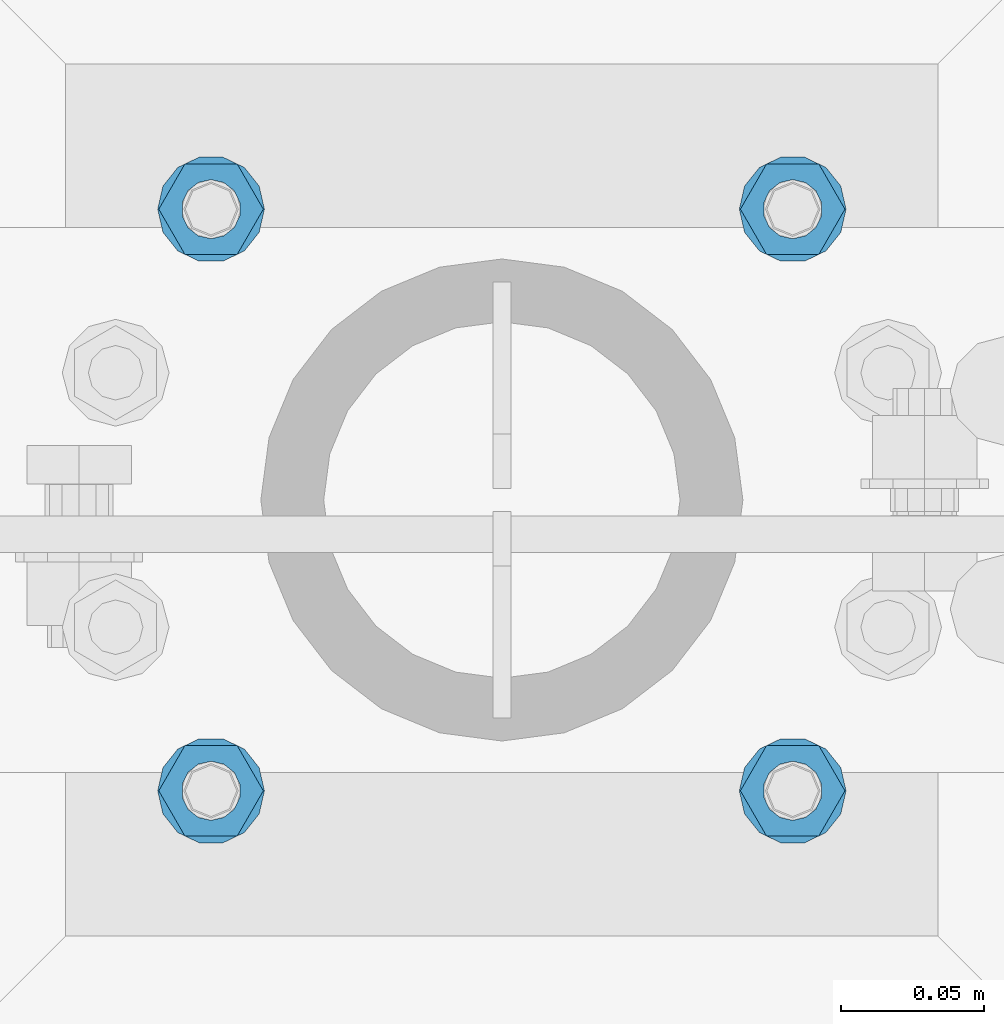
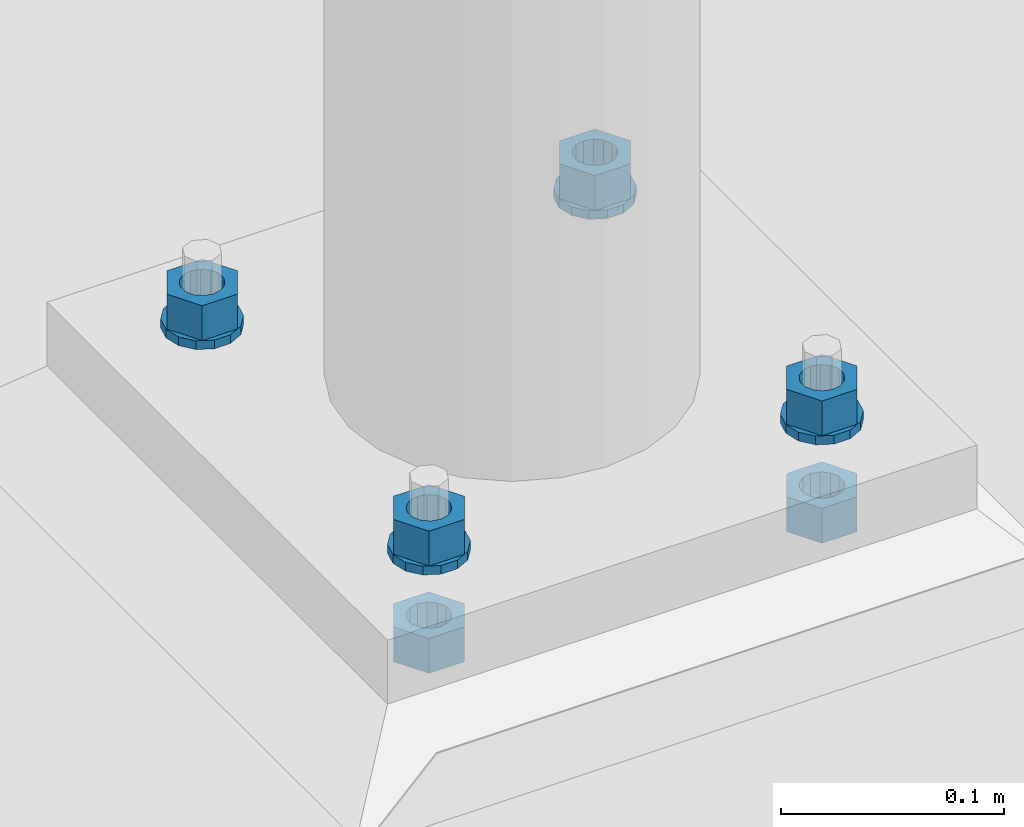
# One storey, part 579 of 975: 10 beams.
"""IFC2X3 building model written with IfcOpenShell, lengths in millimetres."""

from ifc_helpers import new_model, si_unit, frame, origin_with_axes, place, context, subcontext, project, spatial, faceted_brep, material, type_object, element, save


model = new_model("IFC2X3")

# Units and contexts
model_context = context("Model", 3, precision=1e-05, world=origin_with_axes())
body_context = subcontext(model_context, "Body", "Model", "MODEL_VIEW")
ifc_project = project(units=[si_unit("LENGTHUNIT", "METRE", prefix="MILLI"), si_unit("AREAUNIT", "SQUARE_METRE"), si_unit("VOLUMEUNIT", "CUBIC_METRE"), si_unit("MASSUNIT", "GRAM", prefix="KILO"), si_unit("TIMEUNIT", "SECOND"), si_unit("PLANEANGLEUNIT", "RADIAN"), si_unit("SOLIDANGLEUNIT", "STERADIAN"), si_unit("THERMODYNAMICTEMPERATUREUNIT", "DEGREE_CELSIUS"), si_unit("LUMINOUSINTENSITYUNIT", "LUMEN")], contexts=[model_context])

# Site, building, storey
site_placement = place(None, origin_with_axes())
site = spatial("IfcSite", under=ifc_project, at=site_placement, CompositionType="ELEMENT")
building_placement = place(site_placement, origin_with_axes())
building = spatial("IfcBuilding", under=site, at=building_placement, Name="Undefined", CompositionType="ELEMENT")
storey_placement = place(building_placement, origin_with_axes())
storey = spatial("IfcBuildingStorey", under=building, at=storey_placement, Name="Undefined", CompositionType="ELEMENT", Elevation=0.0)

# Beams
ifc_material = material(Name="STEEL/A36")
beam_type_1 = type_object("IfcBeamType", Name="3/4_WASHER", PredefinedType="NOTDEFINED")
beam_1_placement = place(storey_placement, frame((23131.4625015259, 5718.17500305176, -227.0125), z_axis=(0.0, -1.0, 0.0), x_axis=(0.0, 0.0, -1.0)))
element("IfcBeam", 1, at=beam_1_placement, inside=storey, type_object=beam_type_1, material=ifc_material, Name="WASHER", ObjectType="3/4_WASHER", context=body_context, shape_type="Brep", body=[
    faceted_brep([(0.0, -18.6499996185303, 0.0), (0.0, -16.8030690426876, -8.09193156902904), (4.76250000000073, -16.8030690426876, -8.09193156902904), (4.76250000000073, -18.6499996185303, 0.0), (0.0, -11.6280845668225, -14.5811568497838), (4.76250000000073, -11.6280845668225, -14.5811568497838), (0.0, -4.15001533340001, -18.1824051902857), (4.76250000000073, -4.15001533340001, -18.1824051902857), (0.0, 4.15001533340001, -18.1824051902857), (4.76250000000073, 4.15001533340001, -18.1824051902857), (0.0, 11.6280845668234, -14.5811568497838), (4.76250000000073, 11.6280845668234, -14.5811568497838), (0.0, 16.8030690426876, -8.09193156902904), (4.76250000000073, 16.8030690426876, -8.09193156902904), (0.0, 18.6499996185303, 0.0), (4.76250000000073, 18.6499996185303, 0.0), (0.0, 16.8030690426876, 8.09193156902904), (4.76250000000073, 16.8030690426876, 8.09193156902904), (0.0, 11.6280845668225, 14.5811568497838), (4.76250000000073, 11.6280845668225, 14.5811568497838), (0.0, 4.15001533340001, 18.1824051902857), (4.76250000000073, 4.15001533340001, 18.1824051902857), (0.0, -4.15001533340001, 18.1824051902857), (4.76250000000073, -4.15001533340001, 18.1824051902857), (0.0, -11.6280845668234, 14.5811568497838), (4.76250000000073, -11.6280845668234, 14.5811568497838), (0.0, -16.8030690426876, 8.09193156902904), (4.76250000000073, -16.8030690426876, 8.09193156902904), (0.0, 0.0, 10.3199996948242), (0.0, 4.47768005528269, 9.29799844179911), (4.76250000000073, 4.47768005528269, 9.29799844179911), (4.76250000000073, 0.0, 10.3199996948242), (0.0, 8.06850066047446, 6.43441456490817), (4.76250000000073, 8.06850066047446, 6.43441456490817), (0.0, 10.0612557561917, 2.29641597052117), (4.76250000000073, 10.0612557561917, 2.29641597052117), (0.0, 10.0612557561917, -2.29641597052117), (4.76250000000073, 10.0612557561917, -2.29641597052117), (0.0, 8.06850066047446, -6.43441456490814), (4.76250000000073, 8.06850066047446, -6.43441456490814), (0.0, 4.47768005528269, -9.29799844179908), (4.76250000000073, 4.47768005528269, -9.29799844179908), (0.0, 0.0, -10.3199996948242), (4.76250000000073, 0.0, -10.3199996948242), (0.0, -4.47768005528269, -9.29799844179911), (4.76250000000073, -4.47768005528269, -9.29799844179911), (0.0, -8.06850066047446, -6.43441456490817), (4.76250000000073, -8.06850066047446, -6.43441456490817), (0.0, -10.0612557561917, -2.29641597052117), (4.76250000000073, -10.0612557561917, -2.29641597052117), (0.0, -10.0612557561917, 2.29641597052117), (4.76250000000073, -10.0612557561917, 2.29641597052117), (0.0, -8.06850066047446, 6.43441456490814), (4.76250000000073, -8.06850066047446, 6.43441456490814), (0.0, -4.47768005528269, 9.29799844179908), (4.76250000000073, -4.47768005528269, 9.29799844179908)], [[[0, 1, 2, 3]], [[1, 4, 5, 2]], [[4, 6, 7, 5]], [[6, 8, 9, 7]], [[8, 10, 11, 9]], [[10, 12, 13, 11]], [[12, 14, 15, 13]], [[14, 16, 17, 15]], [[16, 18, 19, 17]], [[18, 20, 21, 19]], [[20, 22, 23, 21]], [[22, 24, 25, 23]], [[24, 26, 27, 25]], [[26, 0, 3, 27]], [[28, 29, 30, 31]], [[29, 32, 33, 30]], [[32, 34, 35, 33]], [[34, 36, 37, 35]], [[36, 38, 39, 37]], [[38, 40, 41, 39]], [[40, 42, 43, 41]], [[42, 44, 45, 43]], [[44, 46, 47, 45]], [[46, 48, 49, 47]], [[48, 50, 51, 49]], [[50, 52, 53, 51]], [[52, 54, 55, 53]], [[54, 28, 31, 55]], [[5, 7, 9, 11, 13, 15, 17, 19, 21, 23, 25, 27, 3, 2], [33, 35, 37, 39, 41, 43, 45, 47, 49, 51, 53, 55, 31, 30]], [[26, 24, 22, 20, 18, 16, 14, 12, 10, 8, 6, 4, 1, 0], [54, 52, 50, 48, 46, 44, 42, 40, 38, 36, 34, 32, 29, 28]]]),
])
beam_2_placement = place(storey_placement, frame((23334.6624984741, 5718.17500305176, -227.0125), z_axis=(0.0, 1.0, 0.0), x_axis=(0.0, 0.0, -1.0)))
element("IfcBeam", 2, at=beam_2_placement, inside=storey, type_object=beam_type_1, material=ifc_material, Name="WASHER", ObjectType="3/4_WASHER", context=body_context, shape_type="Brep", body=[
    faceted_brep([(0.0, -18.6499996185303, 0.0), (0.0, -16.8030690426876, -8.09193156902904), (4.76250000000073, -16.8030690426876, -8.09193156902904), (4.76250000000073, -18.6499996185303, 0.0), (0.0, -11.6280845668225, -14.5811568497838), (4.76250000000073, -11.6280845668225, -14.5811568497838), (0.0, -4.15001533340001, -18.1824051902857), (4.76250000000073, -4.15001533340001, -18.1824051902857), (0.0, 4.15001533340001, -18.1824051902857), (4.76250000000073, 4.15001533340001, -18.1824051902857), (0.0, 11.6280845668234, -14.5811568497838), (4.76250000000073, 11.6280845668234, -14.5811568497838), (0.0, 16.8030690426876, -8.09193156902904), (4.76250000000073, 16.8030690426876, -8.09193156902904), (0.0, 18.6499996185303, 0.0), (4.76250000000073, 18.6499996185303, 0.0), (0.0, 16.8030690426876, 8.09193156902904), (4.76250000000073, 16.8030690426876, 8.09193156902904), (0.0, 11.6280845668225, 14.5811568497838), (4.76250000000073, 11.6280845668225, 14.5811568497838), (0.0, 4.15001533340001, 18.1824051902857), (4.76250000000073, 4.15001533340001, 18.1824051902857), (0.0, -4.15001533340001, 18.1824051902857), (4.76250000000073, -4.15001533340001, 18.1824051902857), (0.0, -11.6280845668234, 14.5811568497838), (4.76250000000073, -11.6280845668234, 14.5811568497838), (0.0, -16.8030690426876, 8.09193156902904), (4.76250000000073, -16.8030690426876, 8.09193156902904), (0.0, 0.0, 10.3199996948242), (0.0, 4.47768005528269, 9.29799844179911), (4.76250000000073, 4.47768005528269, 9.29799844179911), (4.76250000000073, 0.0, 10.3199996948242), (0.0, 8.06850066047446, 6.43441456490817), (4.76250000000073, 8.06850066047446, 6.43441456490817), (0.0, 10.0612557561917, 2.29641597052117), (4.76250000000073, 10.0612557561917, 2.29641597052117), (0.0, 10.0612557561917, -2.29641597052117), (4.76250000000073, 10.0612557561917, -2.29641597052117), (0.0, 8.06850066047446, -6.43441456490814), (4.76250000000073, 8.06850066047446, -6.43441456490814), (0.0, 4.47768005528269, -9.29799844179908), (4.76250000000073, 4.47768005528269, -9.29799844179908), (0.0, 0.0, -10.3199996948242), (4.76250000000073, 0.0, -10.3199996948242), (0.0, -4.47768005528269, -9.29799844179911), (4.76250000000073, -4.47768005528269, -9.29799844179911), (0.0, -8.06850066047446, -6.43441456490817), (4.76250000000073, -8.06850066047446, -6.43441456490817), (0.0, -10.0612557561917, -2.29641597052117), (4.76250000000073, -10.0612557561917, -2.29641597052117), (0.0, -10.0612557561917, 2.29641597052117), (4.76250000000073, -10.0612557561917, 2.29641597052117), (0.0, -8.06850066047446, 6.43441456490814), (4.76250000000073, -8.06850066047446, 6.43441456490814), (0.0, -4.47768005528269, 9.29799844179908), (4.76250000000073, -4.47768005528269, 9.29799844179908)], [[[0, 1, 2, 3]], [[1, 4, 5, 2]], [[4, 6, 7, 5]], [[6, 8, 9, 7]], [[8, 10, 11, 9]], [[10, 12, 13, 11]], [[12, 14, 15, 13]], [[14, 16, 17, 15]], [[16, 18, 19, 17]], [[18, 20, 21, 19]], [[20, 22, 23, 21]], [[22, 24, 25, 23]], [[24, 26, 27, 25]], [[26, 0, 3, 27]], [[28, 29, 30, 31]], [[29, 32, 33, 30]], [[32, 34, 35, 33]], [[34, 36, 37, 35]], [[36, 38, 39, 37]], [[38, 40, 41, 39]], [[40, 42, 43, 41]], [[42, 44, 45, 43]], [[44, 46, 47, 45]], [[46, 48, 49, 47]], [[48, 50, 51, 49]], [[50, 52, 53, 51]], [[52, 54, 55, 53]], [[54, 28, 31, 55]], [[5, 7, 9, 11, 13, 15, 17, 19, 21, 23, 25, 27, 3, 2], [33, 35, 37, 39, 41, 43, 45, 47, 49, 51, 53, 55, 31, 30]], [[26, 24, 22, 20, 18, 16, 14, 12, 10, 8, 6, 4, 1, 0], [54, 52, 50, 48, 46, 44, 42, 40, 38, 36, 34, 32, 29, 28]]]),
])
beam_3_placement = place(storey_placement, frame((23131.4625015259, 5921.375, -227.0125), z_axis=(0.0, -1.0, 0.0), x_axis=(0.0, 0.0, -1.0)))
element("IfcBeam", 3, at=beam_3_placement, inside=storey, type_object=beam_type_1, material=ifc_material, Name="WASHER", ObjectType="3/4_WASHER", context=body_context, shape_type="Brep", body=[
    faceted_brep([(0.0, -18.6499996185303, 0.0), (0.0, -16.8030690426876, -8.09193156902904), (4.76250000000073, -16.8030690426876, -8.09193156902904), (4.76250000000073, -18.6499996185303, 0.0), (0.0, -11.6280845668225, -14.5811568497838), (4.76250000000073, -11.6280845668225, -14.5811568497838), (0.0, -4.15001533340001, -18.1824051902857), (4.76250000000073, -4.15001533340001, -18.1824051902857), (0.0, 4.15001533340001, -18.1824051902857), (4.76250000000073, 4.15001533340001, -18.1824051902857), (0.0, 11.6280845668234, -14.5811568497838), (4.76250000000073, 11.6280845668234, -14.5811568497838), (0.0, 16.8030690426876, -8.09193156902904), (4.76250000000073, 16.8030690426876, -8.09193156902904), (0.0, 18.6499996185303, 0.0), (4.76250000000073, 18.6499996185303, 0.0), (0.0, 16.8030690426876, 8.09193156902904), (4.76250000000073, 16.8030690426876, 8.09193156902904), (0.0, 11.6280845668225, 14.5811568497838), (4.76250000000073, 11.6280845668225, 14.5811568497838), (0.0, 4.15001533340001, 18.1824051902857), (4.76250000000073, 4.15001533340001, 18.1824051902857), (0.0, -4.15001533340001, 18.1824051902857), (4.76250000000073, -4.15001533340001, 18.1824051902857), (0.0, -11.6280845668234, 14.5811568497838), (4.76250000000073, -11.6280845668234, 14.5811568497838), (0.0, -16.8030690426876, 8.09193156902904), (4.76250000000073, -16.8030690426876, 8.09193156902904), (0.0, 0.0, 10.3199996948242), (0.0, 4.47768005528269, 9.29799844179911), (4.76250000000073, 4.47768005528269, 9.29799844179911), (4.76250000000073, 0.0, 10.3199996948242), (0.0, 8.06850066047446, 6.43441456490817), (4.76250000000073, 8.06850066047446, 6.43441456490817), (0.0, 10.0612557561917, 2.29641597052117), (4.76250000000073, 10.0612557561917, 2.29641597052117), (0.0, 10.0612557561917, -2.29641597052117), (4.76250000000073, 10.0612557561917, -2.29641597052117), (0.0, 8.06850066047446, -6.43441456490814), (4.76250000000073, 8.06850066047446, -6.43441456490814), (0.0, 4.47768005528269, -9.29799844179908), (4.76250000000073, 4.47768005528269, -9.29799844179908), (0.0, 0.0, -10.3199996948242), (4.76250000000073, 0.0, -10.3199996948242), (0.0, -4.47768005528269, -9.29799844179911), (4.76250000000073, -4.47768005528269, -9.29799844179911), (0.0, -8.06850066047446, -6.43441456490817), (4.76250000000073, -8.06850066047446, -6.43441456490817), (0.0, -10.0612557561917, -2.29641597052117), (4.76250000000073, -10.0612557561917, -2.29641597052117), (0.0, -10.0612557561917, 2.29641597052117), (4.76250000000073, -10.0612557561917, 2.29641597052117), (0.0, -8.06850066047446, 6.43441456490814), (4.76250000000073, -8.06850066047446, 6.43441456490814), (0.0, -4.47768005528269, 9.29799844179908), (4.76250000000073, -4.47768005528269, 9.29799844179908)], [[[0, 1, 2, 3]], [[1, 4, 5, 2]], [[4, 6, 7, 5]], [[6, 8, 9, 7]], [[8, 10, 11, 9]], [[10, 12, 13, 11]], [[12, 14, 15, 13]], [[14, 16, 17, 15]], [[16, 18, 19, 17]], [[18, 20, 21, 19]], [[20, 22, 23, 21]], [[22, 24, 25, 23]], [[24, 26, 27, 25]], [[26, 0, 3, 27]], [[28, 29, 30, 31]], [[29, 32, 33, 30]], [[32, 34, 35, 33]], [[34, 36, 37, 35]], [[36, 38, 39, 37]], [[38, 40, 41, 39]], [[40, 42, 43, 41]], [[42, 44, 45, 43]], [[44, 46, 47, 45]], [[46, 48, 49, 47]], [[48, 50, 51, 49]], [[50, 52, 53, 51]], [[52, 54, 55, 53]], [[54, 28, 31, 55]], [[5, 7, 9, 11, 13, 15, 17, 19, 21, 23, 25, 27, 3, 2], [33, 35, 37, 39, 41, 43, 45, 47, 49, 51, 53, 55, 31, 30]], [[26, 24, 22, 20, 18, 16, 14, 12, 10, 8, 6, 4, 1, 0], [54, 52, 50, 48, 46, 44, 42, 40, 38, 36, 34, 32, 29, 28]]]),
])
beam_4_placement = place(storey_placement, frame((23334.6624984741, 5921.375, -227.0125), z_axis=(0.0, 1.0, 0.0), x_axis=(0.0, 0.0, -1.0)))
element("IfcBeam", 4, at=beam_4_placement, inside=storey, type_object=beam_type_1, material=ifc_material, Name="WASHER", ObjectType="3/4_WASHER", context=body_context, shape_type="Brep", body=[
    faceted_brep([(0.0, -18.6499996185303, 0.0), (0.0, -16.8030690426876, -8.09193156902904), (4.76250000000073, -16.8030690426876, -8.09193156902904), (4.76250000000073, -18.6499996185303, 0.0), (0.0, -11.6280845668225, -14.5811568497838), (4.76250000000073, -11.6280845668225, -14.5811568497838), (0.0, -4.15001533340001, -18.1824051902857), (4.76250000000073, -4.15001533340001, -18.1824051902857), (0.0, 4.15001533340001, -18.1824051902857), (4.76250000000073, 4.15001533340001, -18.1824051902857), (0.0, 11.6280845668234, -14.5811568497838), (4.76250000000073, 11.6280845668234, -14.5811568497838), (0.0, 16.8030690426876, -8.09193156902904), (4.76250000000073, 16.8030690426876, -8.09193156902904), (0.0, 18.6499996185303, 0.0), (4.76250000000073, 18.6499996185303, 0.0), (0.0, 16.8030690426876, 8.09193156902904), (4.76250000000073, 16.8030690426876, 8.09193156902904), (0.0, 11.6280845668225, 14.5811568497838), (4.76250000000073, 11.6280845668225, 14.5811568497838), (0.0, 4.15001533340001, 18.1824051902857), (4.76250000000073, 4.15001533340001, 18.1824051902857), (0.0, -4.15001533340001, 18.1824051902857), (4.76250000000073, -4.15001533340001, 18.1824051902857), (0.0, -11.6280845668234, 14.5811568497838), (4.76250000000073, -11.6280845668234, 14.5811568497838), (0.0, -16.8030690426876, 8.09193156902904), (4.76250000000073, -16.8030690426876, 8.09193156902904), (0.0, 0.0, 10.3199996948242), (0.0, 4.47768005528269, 9.29799844179911), (4.76250000000073, 4.47768005528269, 9.29799844179911), (4.76250000000073, 0.0, 10.3199996948242), (0.0, 8.06850066047446, 6.43441456490817), (4.76250000000073, 8.06850066047446, 6.43441456490817), (0.0, 10.0612557561917, 2.29641597052117), (4.76250000000073, 10.0612557561917, 2.29641597052117), (0.0, 10.0612557561917, -2.29641597052117), (4.76250000000073, 10.0612557561917, -2.29641597052117), (0.0, 8.06850066047446, -6.43441456490814), (4.76250000000073, 8.06850066047446, -6.43441456490814), (0.0, 4.47768005528269, -9.29799844179908), (4.76250000000073, 4.47768005528269, -9.29799844179908), (0.0, 0.0, -10.3199996948242), (4.76250000000073, 0.0, -10.3199996948242), (0.0, -4.47768005528269, -9.29799844179911), (4.76250000000073, -4.47768005528269, -9.29799844179911), (0.0, -8.06850066047446, -6.43441456490817), (4.76250000000073, -8.06850066047446, -6.43441456490817), (0.0, -10.0612557561917, -2.29641597052117), (4.76250000000073, -10.0612557561917, -2.29641597052117), (0.0, -10.0612557561917, 2.29641597052117), (4.76250000000073, -10.0612557561917, 2.29641597052117), (0.0, -8.06850066047446, 6.43441456490814), (4.76250000000073, -8.06850066047446, 6.43441456490814), (0.0, -4.47768005528269, 9.29799844179908), (4.76250000000073, -4.47768005528269, 9.29799844179908)], [[[0, 1, 2, 3]], [[1, 4, 5, 2]], [[4, 6, 7, 5]], [[6, 8, 9, 7]], [[8, 10, 11, 9]], [[10, 12, 13, 11]], [[12, 14, 15, 13]], [[14, 16, 17, 15]], [[16, 18, 19, 17]], [[18, 20, 21, 19]], [[20, 22, 23, 21]], [[22, 24, 25, 23]], [[24, 26, 27, 25]], [[26, 0, 3, 27]], [[28, 29, 30, 31]], [[29, 32, 33, 30]], [[32, 34, 35, 33]], [[34, 36, 37, 35]], [[36, 38, 39, 37]], [[38, 40, 41, 39]], [[40, 42, 43, 41]], [[42, 44, 45, 43]], [[44, 46, 47, 45]], [[46, 48, 49, 47]], [[48, 50, 51, 49]], [[50, 52, 53, 51]], [[52, 54, 55, 53]], [[54, 28, 31, 55]], [[5, 7, 9, 11, 13, 15, 17, 19, 21, 23, 25, 27, 3, 2], [33, 35, 37, 39, 41, 43, 45, 47, 49, 51, 53, 55, 31, 30]], [[26, 24, 22, 20, 18, 16, 14, 12, 10, 8, 6, 4, 1, 0], [54, 52, 50, 48, 46, 44, 42, 40, 38, 36, 34, 32, 29, 28]]]),
])
beam_type_2 = type_object("IfcBeamType", Name="3/4_HEAVY_HEX_NUT", PredefinedType="NOTDEFINED")
beam_5_placement = place(storey_placement, frame((23131.4625015259, 5718.17500305176, -207.962500000001), z_axis=(0.0, -1.0, 0.0), x_axis=(0.0, 0.0, -1.0)))
element("IfcBeam", 5, at=beam_5_placement, inside=storey, type_object=beam_type_2, material=ifc_material, Name="NUT", ObjectType="3/4_HEAVY_HEX_NUT", context=body_context, shape_type="Brep", body=[
    faceted_brep([(0.0, -18.2600002288818, 0.0), (0.0, -9.13000011444092, -15.8100004196167), (19.0499999999993, -9.13000011444092, -15.8100004196167), (19.0499999999993, -18.2600002288818, 0.0), (0.0, 9.13000011444092, -15.8100004196167), (19.0499999999993, 9.13000011444092, -15.8100004196167), (0.0, 18.2600002288818, 0.0), (19.0499999999993, 18.2600002288818, 0.0), (0.0, 9.13000011444092, 15.8100004196167), (19.0499999999993, 9.13000011444092, 15.8100004196167), (0.0, -9.13000011444092, 15.8100004196167), (19.0499999999993, -9.13000011444092, 15.8100004196167), (0.0, 0.0, 10.3199996948242), (0.0, 4.47768005528269, 9.29799844179911), (19.0499999999993, 4.47768005528269, 9.29799844179911), (19.0499999999993, 0.0, 10.3199996948242), (0.0, 8.06850066047446, 6.43441456490817), (19.0499999999993, 8.06850066047446, 6.43441456490817), (0.0, 10.0612557561917, 2.29641597052117), (19.0499999999993, 10.0612557561917, 2.29641597052117), (0.0, 10.0612557561917, -2.29641597052117), (19.0499999999993, 10.0612557561917, -2.29641597052117), (0.0, 8.06850066047446, -6.43441456490814), (19.0499999999993, 8.06850066047446, -6.43441456490814), (0.0, 4.47768005528269, -9.29799844179908), (19.0499999999993, 4.47768005528269, -9.29799844179908), (0.0, 0.0, -10.3199996948242), (19.0499999999993, 0.0, -10.3199996948242), (0.0, -4.47768005528269, -9.29799844179911), (19.0499999999993, -4.47768005528269, -9.29799844179911), (0.0, -8.06850066047446, -6.43441456490817), (19.0499999999993, -8.06850066047446, -6.43441456490817), (0.0, -10.0612557561917, -2.29641597052117), (19.0499999999993, -10.0612557561917, -2.29641597052117), (0.0, -10.0612557561917, 2.29641597052117), (19.0499999999993, -10.0612557561917, 2.29641597052117), (0.0, -8.06850066047446, 6.43441456490814), (19.0499999999993, -8.06850066047446, 6.43441456490814), (0.0, -4.47768005528269, 9.29799844179908), (19.0499999999993, -4.47768005528269, 9.29799844179908)], [[[0, 1, 2, 3]], [[1, 4, 5, 2]], [[4, 6, 7, 5]], [[6, 8, 9, 7]], [[8, 10, 11, 9]], [[10, 0, 3, 11]], [[12, 13, 14, 15]], [[13, 16, 17, 14]], [[16, 18, 19, 17]], [[18, 20, 21, 19]], [[20, 22, 23, 21]], [[22, 24, 25, 23]], [[24, 26, 27, 25]], [[26, 28, 29, 27]], [[28, 30, 31, 29]], [[30, 32, 33, 31]], [[32, 34, 35, 33]], [[34, 36, 37, 35]], [[36, 38, 39, 37]], [[38, 12, 15, 39]], [[5, 7, 9, 11, 3, 2], [17, 19, 21, 23, 25, 27, 29, 31, 33, 35, 37, 39, 15, 14]], [[10, 8, 6, 4, 1, 0], [38, 36, 34, 32, 30, 28, 26, 24, 22, 20, 18, 16, 13, 12]]]),
])
beam_6_placement = place(storey_placement, frame((23334.6624984741, 5718.17500305176, -207.962500000001), z_axis=(0.0, 1.0, 0.0), x_axis=(0.0, 0.0, -1.0)))
element("IfcBeam", 6, at=beam_6_placement, inside=storey, type_object=beam_type_2, material=ifc_material, Name="NUT", ObjectType="3/4_HEAVY_HEX_NUT", context=body_context, shape_type="Brep", body=[
    faceted_brep([(0.0, -18.2600002288818, 0.0), (0.0, -9.13000011444092, -15.8100004196167), (19.0499999999993, -9.13000011444092, -15.8100004196167), (19.0499999999993, -18.2600002288818, 0.0), (0.0, 9.13000011444092, -15.8100004196167), (19.0499999999993, 9.13000011444092, -15.8100004196167), (0.0, 18.2600002288818, 0.0), (19.0499999999993, 18.2600002288818, 0.0), (0.0, 9.13000011444092, 15.8100004196167), (19.0499999999993, 9.13000011444092, 15.8100004196167), (0.0, -9.13000011444092, 15.8100004196167), (19.0499999999993, -9.13000011444092, 15.8100004196167), (0.0, 0.0, 10.3199996948242), (0.0, 4.47768005528269, 9.29799844179911), (19.0499999999993, 4.47768005528269, 9.29799844179911), (19.0499999999993, 0.0, 10.3199996948242), (0.0, 8.06850066047446, 6.43441456490817), (19.0499999999993, 8.06850066047446, 6.43441456490817), (0.0, 10.0612557561917, 2.29641597052117), (19.0499999999993, 10.0612557561917, 2.29641597052117), (0.0, 10.0612557561917, -2.29641597052117), (19.0499999999993, 10.0612557561917, -2.29641597052117), (0.0, 8.06850066047446, -6.43441456490814), (19.0499999999993, 8.06850066047446, -6.43441456490814), (0.0, 4.47768005528269, -9.29799844179908), (19.0499999999993, 4.47768005528269, -9.29799844179908), (0.0, 0.0, -10.3199996948242), (19.0499999999993, 0.0, -10.3199996948242), (0.0, -4.47768005528269, -9.29799844179911), (19.0499999999993, -4.47768005528269, -9.29799844179911), (0.0, -8.06850066047446, -6.43441456490817), (19.0499999999993, -8.06850066047446, -6.43441456490817), (0.0, -10.0612557561917, -2.29641597052117), (19.0499999999993, -10.0612557561917, -2.29641597052117), (0.0, -10.0612557561917, 2.29641597052117), (19.0499999999993, -10.0612557561917, 2.29641597052117), (0.0, -8.06850066047446, 6.43441456490814), (19.0499999999993, -8.06850066047446, 6.43441456490814), (0.0, -4.47768005528269, 9.29799844179908), (19.0499999999993, -4.47768005528269, 9.29799844179908)], [[[0, 1, 2, 3]], [[1, 4, 5, 2]], [[4, 6, 7, 5]], [[6, 8, 9, 7]], [[8, 10, 11, 9]], [[10, 0, 3, 11]], [[12, 13, 14, 15]], [[13, 16, 17, 14]], [[16, 18, 19, 17]], [[18, 20, 21, 19]], [[20, 22, 23, 21]], [[22, 24, 25, 23]], [[24, 26, 27, 25]], [[26, 28, 29, 27]], [[28, 30, 31, 29]], [[30, 32, 33, 31]], [[32, 34, 35, 33]], [[34, 36, 37, 35]], [[36, 38, 39, 37]], [[38, 12, 15, 39]], [[5, 7, 9, 11, 3, 2], [17, 19, 21, 23, 25, 27, 29, 31, 33, 35, 37, 39, 15, 14]], [[10, 8, 6, 4, 1, 0], [38, 36, 34, 32, 30, 28, 26, 24, 22, 20, 18, 16, 13, 12]]]),
])
beam_7_placement = place(storey_placement, frame((23131.4625015259, 5921.375, -207.962500000001), z_axis=(0.0, -1.0, 0.0), x_axis=(0.0, 0.0, -1.0)))
element("IfcBeam", 7, at=beam_7_placement, inside=storey, type_object=beam_type_2, material=ifc_material, Name="NUT", ObjectType="3/4_HEAVY_HEX_NUT", context=body_context, shape_type="Brep", body=[
    faceted_brep([(0.0, -18.2600002288818, 0.0), (0.0, -9.13000011444092, -15.8100004196167), (19.0499999999993, -9.13000011444092, -15.8100004196167), (19.0499999999993, -18.2600002288818, 0.0), (0.0, 9.13000011444092, -15.8100004196167), (19.0499999999993, 9.13000011444092, -15.8100004196167), (0.0, 18.2600002288818, 0.0), (19.0499999999993, 18.2600002288818, 0.0), (0.0, 9.13000011444092, 15.8100004196167), (19.0499999999993, 9.13000011444092, 15.8100004196167), (0.0, -9.13000011444092, 15.8100004196167), (19.0499999999993, -9.13000011444092, 15.8100004196167), (0.0, 0.0, 10.3199996948242), (0.0, 4.47768005528269, 9.29799844179911), (19.0499999999993, 4.47768005528269, 9.29799844179911), (19.0499999999993, 0.0, 10.3199996948242), (0.0, 8.06850066047446, 6.43441456490817), (19.0499999999993, 8.06850066047446, 6.43441456490817), (0.0, 10.0612557561917, 2.29641597052117), (19.0499999999993, 10.0612557561917, 2.29641597052117), (0.0, 10.0612557561917, -2.29641597052117), (19.0499999999993, 10.0612557561917, -2.29641597052117), (0.0, 8.06850066047446, -6.43441456490814), (19.0499999999993, 8.06850066047446, -6.43441456490814), (0.0, 4.47768005528269, -9.29799844179908), (19.0499999999993, 4.47768005528269, -9.29799844179908), (0.0, 0.0, -10.3199996948242), (19.0499999999993, 0.0, -10.3199996948242), (0.0, -4.47768005528269, -9.29799844179911), (19.0499999999993, -4.47768005528269, -9.29799844179911), (0.0, -8.06850066047446, -6.43441456490817), (19.0499999999993, -8.06850066047446, -6.43441456490817), (0.0, -10.0612557561917, -2.29641597052117), (19.0499999999993, -10.0612557561917, -2.29641597052117), (0.0, -10.0612557561917, 2.29641597052117), (19.0499999999993, -10.0612557561917, 2.29641597052117), (0.0, -8.06850066047446, 6.43441456490814), (19.0499999999993, -8.06850066047446, 6.43441456490814), (0.0, -4.47768005528269, 9.29799844179908), (19.0499999999993, -4.47768005528269, 9.29799844179908)], [[[0, 1, 2, 3]], [[1, 4, 5, 2]], [[4, 6, 7, 5]], [[6, 8, 9, 7]], [[8, 10, 11, 9]], [[10, 0, 3, 11]], [[12, 13, 14, 15]], [[13, 16, 17, 14]], [[16, 18, 19, 17]], [[18, 20, 21, 19]], [[20, 22, 23, 21]], [[22, 24, 25, 23]], [[24, 26, 27, 25]], [[26, 28, 29, 27]], [[28, 30, 31, 29]], [[30, 32, 33, 31]], [[32, 34, 35, 33]], [[34, 36, 37, 35]], [[36, 38, 39, 37]], [[38, 12, 15, 39]], [[5, 7, 9, 11, 3, 2], [17, 19, 21, 23, 25, 27, 29, 31, 33, 35, 37, 39, 15, 14]], [[10, 8, 6, 4, 1, 0], [38, 36, 34, 32, 30, 28, 26, 24, 22, 20, 18, 16, 13, 12]]]),
])
beam_8_placement = place(storey_placement, frame((23334.6624984741, 5921.375, -207.962500000001), z_axis=(0.0, 1.0, 0.0), x_axis=(0.0, 0.0, -1.0)))
element("IfcBeam", 8, at=beam_8_placement, inside=storey, type_object=beam_type_2, material=ifc_material, Name="NUT", ObjectType="3/4_HEAVY_HEX_NUT", context=body_context, shape_type="Brep", body=[
    faceted_brep([(0.0, -18.2600002288818, 0.0), (0.0, -9.13000011444092, -15.8100004196167), (19.0499999999993, -9.13000011444092, -15.8100004196167), (19.0499999999993, -18.2600002288818, 0.0), (0.0, 9.13000011444092, -15.8100004196167), (19.0499999999993, 9.13000011444092, -15.8100004196167), (0.0, 18.2600002288818, 0.0), (19.0499999999993, 18.2600002288818, 0.0), (0.0, 9.13000011444092, 15.8100004196167), (19.0499999999993, 9.13000011444092, 15.8100004196167), (0.0, -9.13000011444092, 15.8100004196167), (19.0499999999993, -9.13000011444092, 15.8100004196167), (0.0, 0.0, 10.3199996948242), (0.0, 4.47768005528269, 9.29799844179911), (19.0499999999993, 4.47768005528269, 9.29799844179911), (19.0499999999993, 0.0, 10.3199996948242), (0.0, 8.06850066047446, 6.43441456490817), (19.0499999999993, 8.06850066047446, 6.43441456490817), (0.0, 10.0612557561917, 2.29641597052117), (19.0499999999993, 10.0612557561917, 2.29641597052117), (0.0, 10.0612557561917, -2.29641597052117), (19.0499999999993, 10.0612557561917, -2.29641597052117), (0.0, 8.06850066047446, -6.43441456490814), (19.0499999999993, 8.06850066047446, -6.43441456490814), (0.0, 4.47768005528269, -9.29799844179908), (19.0499999999993, 4.47768005528269, -9.29799844179908), (0.0, 0.0, -10.3199996948242), (19.0499999999993, 0.0, -10.3199996948242), (0.0, -4.47768005528269, -9.29799844179911), (19.0499999999993, -4.47768005528269, -9.29799844179911), (0.0, -8.06850066047446, -6.43441456490817), (19.0499999999993, -8.06850066047446, -6.43441456490817), (0.0, -10.0612557561917, -2.29641597052117), (19.0499999999993, -10.0612557561917, -2.29641597052117), (0.0, -10.0612557561917, 2.29641597052117), (19.0499999999993, -10.0612557561917, 2.29641597052117), (0.0, -8.06850066047446, 6.43441456490814), (19.0499999999993, -8.06850066047446, 6.43441456490814), (0.0, -4.47768005528269, 9.29799844179908), (19.0499999999993, -4.47768005528269, 9.29799844179908)], [[[0, 1, 2, 3]], [[1, 4, 5, 2]], [[4, 6, 7, 5]], [[6, 8, 9, 7]], [[8, 10, 11, 9]], [[10, 0, 3, 11]], [[12, 13, 14, 15]], [[13, 16, 17, 14]], [[16, 18, 19, 17]], [[18, 20, 21, 19]], [[20, 22, 23, 21]], [[22, 24, 25, 23]], [[24, 26, 27, 25]], [[26, 28, 29, 27]], [[28, 30, 31, 29]], [[30, 32, 33, 31]], [[32, 34, 35, 33]], [[34, 36, 37, 35]], [[36, 38, 39, 37]], [[38, 12, 15, 39]], [[5, 7, 9, 11, 3, 2], [17, 19, 21, 23, 25, 27, 29, 31, 33, 35, 37, 39, 15, 14]], [[10, 8, 6, 4, 1, 0], [38, 36, 34, 32, 30, 28, 26, 24, 22, 20, 18, 16, 13, 12]]]),
])
beam_9_placement = place(storey_placement, frame((23131.4625015259, 5718.17500305176, -266.7), z_axis=(0.0, -1.0, 0.0), x_axis=(0.0, 0.0, -1.0)))
element("IfcBeam", 9, at=beam_9_placement, inside=storey, type_object=beam_type_2, material=ifc_material, Name="NUT", ObjectType="3/4_HEAVY_HEX_NUT", context=body_context, shape_type="Brep", body=[
    faceted_brep([(0.0, -18.2600002288818, 0.0), (0.0, -9.13000011444092, -15.8100004196167), (19.0499999999993, -9.13000011444092, -15.8100004196167), (19.0499999999993, -18.2600002288818, 0.0), (0.0, 9.13000011444092, -15.8100004196167), (19.0499999999993, 9.13000011444092, -15.8100004196167), (0.0, 18.2600002288818, 0.0), (19.0499999999993, 18.2600002288818, 0.0), (0.0, 9.13000011444092, 15.8100004196167), (19.0499999999993, 9.13000011444092, 15.8100004196167), (0.0, -9.13000011444092, 15.8100004196167), (19.0499999999993, -9.13000011444092, 15.8100004196167), (0.0, 0.0, 10.3199996948242), (0.0, 4.47768005528269, 9.29799844179911), (19.0499999999993, 4.47768005528269, 9.29799844179911), (19.0499999999993, 0.0, 10.3199996948242), (0.0, 8.06850066047446, 6.43441456490817), (19.0499999999993, 8.06850066047446, 6.43441456490817), (0.0, 10.0612557561917, 2.29641597052117), (19.0499999999993, 10.0612557561917, 2.29641597052117), (0.0, 10.0612557561917, -2.29641597052117), (19.0499999999993, 10.0612557561917, -2.29641597052117), (0.0, 8.06850066047446, -6.43441456490814), (19.0499999999993, 8.06850066047446, -6.43441456490814), (0.0, 4.47768005528269, -9.29799844179908), (19.0499999999993, 4.47768005528269, -9.29799844179908), (0.0, 0.0, -10.3199996948242), (19.0499999999993, 0.0, -10.3199996948242), (0.0, -4.47768005528269, -9.29799844179911), (19.0499999999993, -4.47768005528269, -9.29799844179911), (0.0, -8.06850066047446, -6.43441456490817), (19.0499999999993, -8.06850066047446, -6.43441456490817), (0.0, -10.0612557561917, -2.29641597052117), (19.0499999999993, -10.0612557561917, -2.29641597052117), (0.0, -10.0612557561917, 2.29641597052117), (19.0499999999993, -10.0612557561917, 2.29641597052117), (0.0, -8.06850066047446, 6.43441456490814), (19.0499999999993, -8.06850066047446, 6.43441456490814), (0.0, -4.47768005528269, 9.29799844179908), (19.0499999999993, -4.47768005528269, 9.29799844179908)], [[[0, 1, 2, 3]], [[1, 4, 5, 2]], [[4, 6, 7, 5]], [[6, 8, 9, 7]], [[8, 10, 11, 9]], [[10, 0, 3, 11]], [[12, 13, 14, 15]], [[13, 16, 17, 14]], [[16, 18, 19, 17]], [[18, 20, 21, 19]], [[20, 22, 23, 21]], [[22, 24, 25, 23]], [[24, 26, 27, 25]], [[26, 28, 29, 27]], [[28, 30, 31, 29]], [[30, 32, 33, 31]], [[32, 34, 35, 33]], [[34, 36, 37, 35]], [[36, 38, 39, 37]], [[38, 12, 15, 39]], [[5, 7, 9, 11, 3, 2], [17, 19, 21, 23, 25, 27, 29, 31, 33, 35, 37, 39, 15, 14]], [[10, 8, 6, 4, 1, 0], [38, 36, 34, 32, 30, 28, 26, 24, 22, 20, 18, 16, 13, 12]]]),
])
beam_10_placement = place(storey_placement, frame((23334.6624984741, 5718.17500305176, -266.7), z_axis=(0.0, 1.0, 0.0), x_axis=(0.0, 0.0, -1.0)))
element("IfcBeam", 10, at=beam_10_placement, inside=storey, type_object=beam_type_2, material=ifc_material, Name="NUT", ObjectType="3/4_HEAVY_HEX_NUT", context=body_context, shape_type="Brep", body=[
    faceted_brep([(0.0, -18.2600002288818, 0.0), (0.0, -9.13000011444092, -15.8100004196167), (19.0499999999993, -9.13000011444092, -15.8100004196167), (19.0499999999993, -18.2600002288818, 0.0), (0.0, 9.13000011444092, -15.8100004196167), (19.0499999999993, 9.13000011444092, -15.8100004196167), (0.0, 18.2600002288818, 0.0), (19.0499999999993, 18.2600002288818, 0.0), (0.0, 9.13000011444092, 15.8100004196167), (19.0499999999993, 9.13000011444092, 15.8100004196167), (0.0, -9.13000011444092, 15.8100004196167), (19.0499999999993, -9.13000011444092, 15.8100004196167), (0.0, 0.0, 10.3199996948242), (0.0, 4.47768005528269, 9.29799844179911), (19.0499999999993, 4.47768005528269, 9.29799844179911), (19.0499999999993, 0.0, 10.3199996948242), (0.0, 8.06850066047446, 6.43441456490817), (19.0499999999993, 8.06850066047446, 6.43441456490817), (0.0, 10.0612557561917, 2.29641597052117), (19.0499999999993, 10.0612557561917, 2.29641597052117), (0.0, 10.0612557561917, -2.29641597052117), (19.0499999999993, 10.0612557561917, -2.29641597052117), (0.0, 8.06850066047446, -6.43441456490814), (19.0499999999993, 8.06850066047446, -6.43441456490814), (0.0, 4.47768005528269, -9.29799844179908), (19.0499999999993, 4.47768005528269, -9.29799844179908), (0.0, 0.0, -10.3199996948242), (19.0499999999993, 0.0, -10.3199996948242), (0.0, -4.47768005528269, -9.29799844179911), (19.0499999999993, -4.47768005528269, -9.29799844179911), (0.0, -8.06850066047446, -6.43441456490817), (19.0499999999993, -8.06850066047446, -6.43441456490817), (0.0, -10.0612557561917, -2.29641597052117), (19.0499999999993, -10.0612557561917, -2.29641597052117), (0.0, -10.0612557561917, 2.29641597052117), (19.0499999999993, -10.0612557561917, 2.29641597052117), (0.0, -8.06850066047446, 6.43441456490814), (19.0499999999993, -8.06850066047446, 6.43441456490814), (0.0, -4.47768005528269, 9.29799844179908), (19.0499999999993, -4.47768005528269, 9.29799844179908)], [[[0, 1, 2, 3]], [[1, 4, 5, 2]], [[4, 6, 7, 5]], [[6, 8, 9, 7]], [[8, 10, 11, 9]], [[10, 0, 3, 11]], [[12, 13, 14, 15]], [[13, 16, 17, 14]], [[16, 18, 19, 17]], [[18, 20, 21, 19]], [[20, 22, 23, 21]], [[22, 24, 25, 23]], [[24, 26, 27, 25]], [[26, 28, 29, 27]], [[28, 30, 31, 29]], [[30, 32, 33, 31]], [[32, 34, 35, 33]], [[34, 36, 37, 35]], [[36, 38, 39, 37]], [[38, 12, 15, 39]], [[5, 7, 9, 11, 3, 2], [17, 19, 21, 23, 25, 27, 29, 31, 33, 35, 37, 39, 15, 14]], [[10, 8, 6, 4, 1, 0], [38, 36, 34, 32, 30, 28, 26, 24, 22, 20, 18, 16, 13, 12]]]),
])

save(model, "model.ifc")
